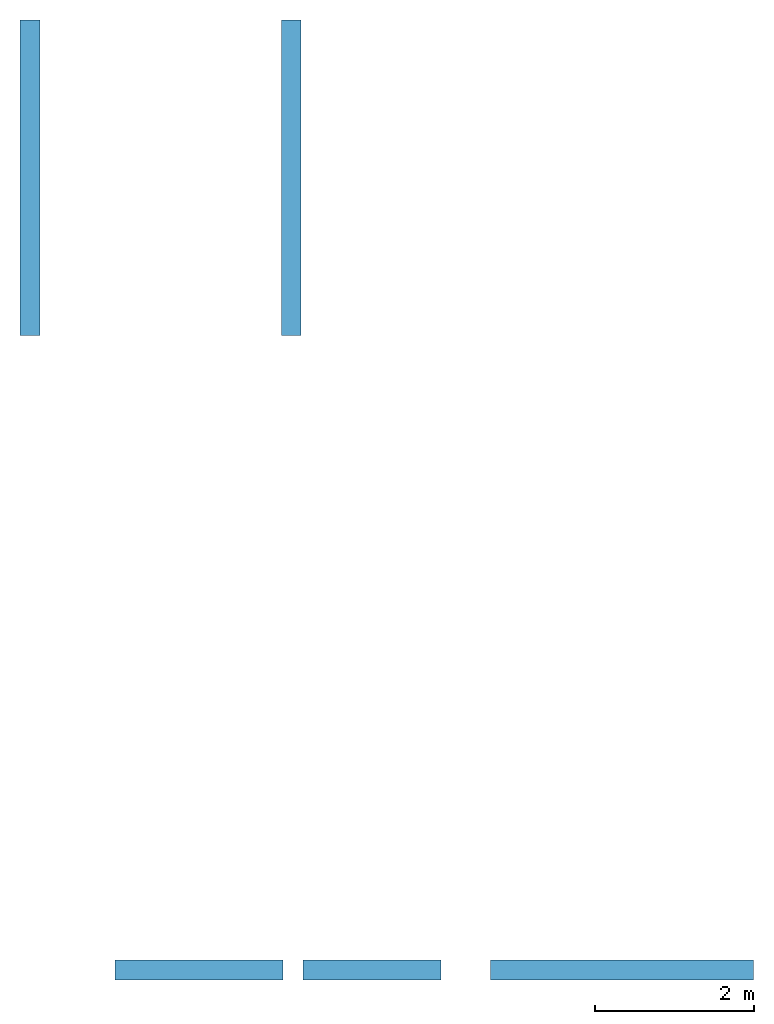
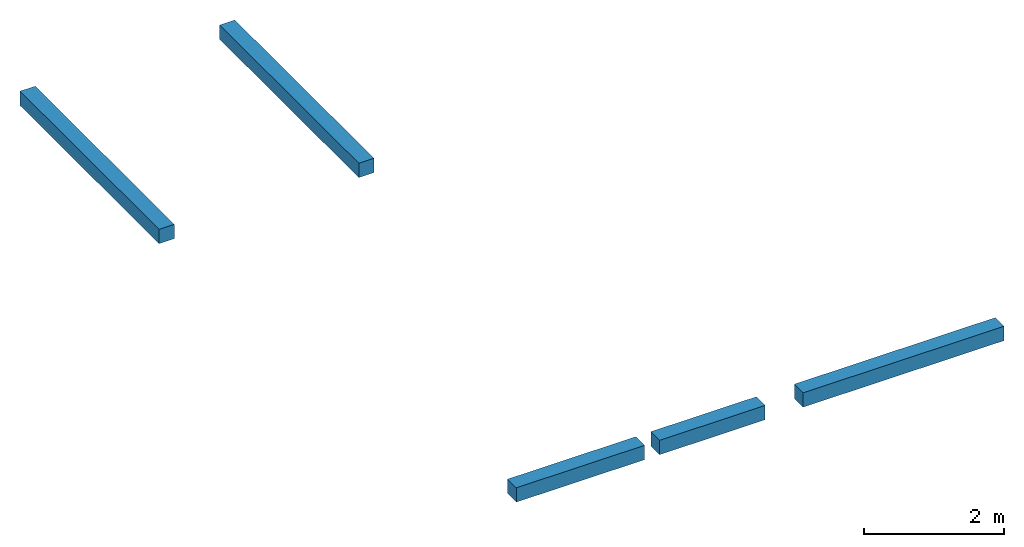
# One storey: 4 walls, 1 opening.
"""IFC2X3 building model written with IfcOpenShell, lengths in millimetres."""

from ifc_helpers import new_model, entity, si_unit, converted_unit, derived_unit, direction, frame, frame_2d, origin, origin_2d_with_axis, place, context, subcontext, project, spatial, rectangle, extrude, material, layer, layer_set, layer_usage, type_object, element, save


model = new_model("IFC2X3")

# Units and contexts
model_context = context("Model", 3, precision=0.01, world=origin(), true_north=direction((6.12303176911189e-17, 1.0)))
context_of_model = context(None, 3, precision=0.01, world=origin(), true_north=direction((6.12303176911189e-17, 1.0)))
body_context = subcontext(model_context, "Body", "Model", "MODEL_VIEW")
ifc_project = project(units=[si_unit("LENGTHUNIT", "METRE", prefix="MILLI"), si_unit("AREAUNIT", "SQUARE_METRE"), si_unit("VOLUMEUNIT", "CUBIC_METRE"), converted_unit("PLANEANGLEUNIT", "DEGREE", entity("IfcRatioMeasure", 0.0174532925199433), si_unit("PLANEANGLEUNIT", "RADIAN"), dimensions=[0, 0, 0, 0, 0, 0, 0]), si_unit("MASSUNIT", "GRAM", prefix="KILO"), si_unit("TIMEUNIT", "SECOND"), si_unit("FREQUENCYUNIT", "HERTZ"), si_unit("THERMODYNAMICTEMPERATUREUNIT", "DEGREE_CELSIUS"), derived_unit("THERMALTRANSMITTANCEUNIT", [(si_unit("MASSUNIT", "GRAM", prefix="KILO"), 1), (si_unit("THERMODYNAMICTEMPERATUREUNIT", "KELVIN"), -1), (si_unit("TIMEUNIT", "SECOND"), -3)]), derived_unit("VOLUMETRICFLOWRATEUNIT", [(si_unit("LENGTHUNIT", "METRE"), 3), (si_unit("TIMEUNIT", "SECOND"), -1)]), si_unit("ELECTRICCURRENTUNIT", "AMPERE"), si_unit("ELECTRICVOLTAGEUNIT", "VOLT"), si_unit("POWERUNIT", "WATT"), si_unit("FORCEUNIT", "NEWTON", prefix="KILO"), si_unit("ILLUMINANCEUNIT", "LUX"), si_unit("LUMINOUSFLUXUNIT", "LUMEN"), si_unit("LUMINOUSINTENSITYUNIT", "CANDELA"), si_unit("PRESSUREUNIT", "PASCAL")], contexts=[model_context, context_of_model])

# Site, building, storey
site_placement = place(None, origin())
site = spatial("IfcSite", under=ifc_project, at=site_placement, CompositionType="ELEMENT")
building_placement = place(site_placement, origin())
building = spatial("IfcBuilding", under=site, at=building_placement, CompositionType="ELEMENT")
storey_placement = place(building_placement, frame((0.0, 0.0, 2950.0)))
storey = spatial("IfcBuildingStorey", under=building, at=storey_placement, Name="Top window indoor", CompositionType="ELEMENT", Elevation=2950.0)

# Wall, opening
ifc_material = material(Name="Default Wall")
ifc_layer = layer(ifc_material, 250.0)
ifc_layer_set = layer_set([ifc_layer], Name="Basic Wall")
ifc_layer_usage_1 = layer_usage(ifc_layer_set, "AXIS2", "NEGATIVE", 125.0)
wall_type = type_object("IfcWallType", Name="Basic Wall", PredefinedType="STANDARD", material=ifc_layer_set)
wall_1_placement = place(storey_placement, frame((-3512.90465447712, 2255.33872415508, 0.0)))
wall_1 = element("IfcWallStandardCase", 1, at=wall_1_placement, inside=storey, type_object=wall_type, material=ifc_layer_usage_1, Name="Basic Wall", ObjectType="Basic Wall", context=body_context, shape_type="SweptSolid", body=[
    extrude(rectangle(XDim=4101.31656169857, YDim=250.0, at=frame_2d((2050.65828084929, 0.0), x_axis=(-1.0, 0.0))), origin(), (0.0, 0.0, 1.0), 249.999999999837),
])
opening_placement = place(storey_placement, frame((-3512.90465447712, 2255.33872415508, 0.0)))
element("IfcOpeningElement", 2, at=opening_placement, cuts=wall_1, Name="Basic Wall:1", ObjectType="Opening", context=body_context, shape_type="SweptSolid", body=[
    extrude(rectangle(XDim=249.999999999837, YDim=250.0, at=origin_2d_with_axis()), frame((2111.31656169857, 0.0, 125.0), z_axis=(1.0, 0.0, 0.0), x_axis=(0.0, 0.0, -1.0)), (0.0, 0.0, 1.0), 250.0),
])

# Walls
ifc_layer_usage_2 = layer_usage(ifc_layer_set, "AXIS2", "NEGATIVE", 125.0)
wall_2_placement = place(storey_placement, frame((1213.41190722145, 2255.33872415507, 0.0)))
element("IfcWallStandardCase", 3, at=wall_2_placement, inside=storey, type_object=wall_type, material=ifc_layer_usage_2, Name="Basic Wall", ObjectType="Basic Wall", context=body_context, shape_type="SweptSolid", body=[
    extrude(rectangle(XDim=3308.6281298869, YDim=250.0, at=frame_2d((1654.31406494345, 2.1316282072803e-14), x_axis=(-1.0, 0.0))), origin(), (0.0, 0.0, 1.0), 249.999999999837),
])
ifc_layer_usage_3 = layer_usage(ifc_layer_set, "AXIS2", "NEGATIVE", 125.0)
wall_3_placement = place(storey_placement, frame((-4586.58809277854, 10245.809718742, 0.0), z_axis=(0.0, 0.0, 1.0), x_axis=(0.0, 1.0, 0.0)))
element("IfcWallStandardCase", 4, at=wall_3_placement, inside=storey, type_object=wall_type, material=ifc_layer_usage_3, Name="Basic Wall", ObjectType="Basic Wall", context=body_context, shape_type="SweptSolid", body=[
    extrude(rectangle(XDim=3970.58547840577, YDim=249.999999999999, at=frame_2d((1985.29273920289, 0.0), x_axis=(-1.0, 0.0))), origin(), (0.0, 0.0, 1.0), 249.999999999837),
])
ifc_layer_usage_4 = layer_usage(ifc_layer_set, "AXIS2", "NEGATIVE", 125.0)
wall_4_placement = place(storey_placement, frame((-1296.58809277854, 10245.809718742, 0.0), z_axis=(0.0, 0.0, 1.0), x_axis=(0.0, 1.0, 0.0)))
element("IfcWallStandardCase", 5, at=wall_4_placement, inside=storey, type_object=wall_type, material=ifc_layer_usage_4, Name="Basic Wall", ObjectType="Basic Wall", context=body_context, shape_type="SweptSolid", body=[
    extrude(rectangle(XDim=3970.58547840576, YDim=250.0, at=frame_2d((1985.29273920288, 6.3948846218409e-14), x_axis=(-1.0, 0.0))), origin(), (0.0, 0.0, 1.0), 249.999999999837),
])

save(model, "model.ifc")
